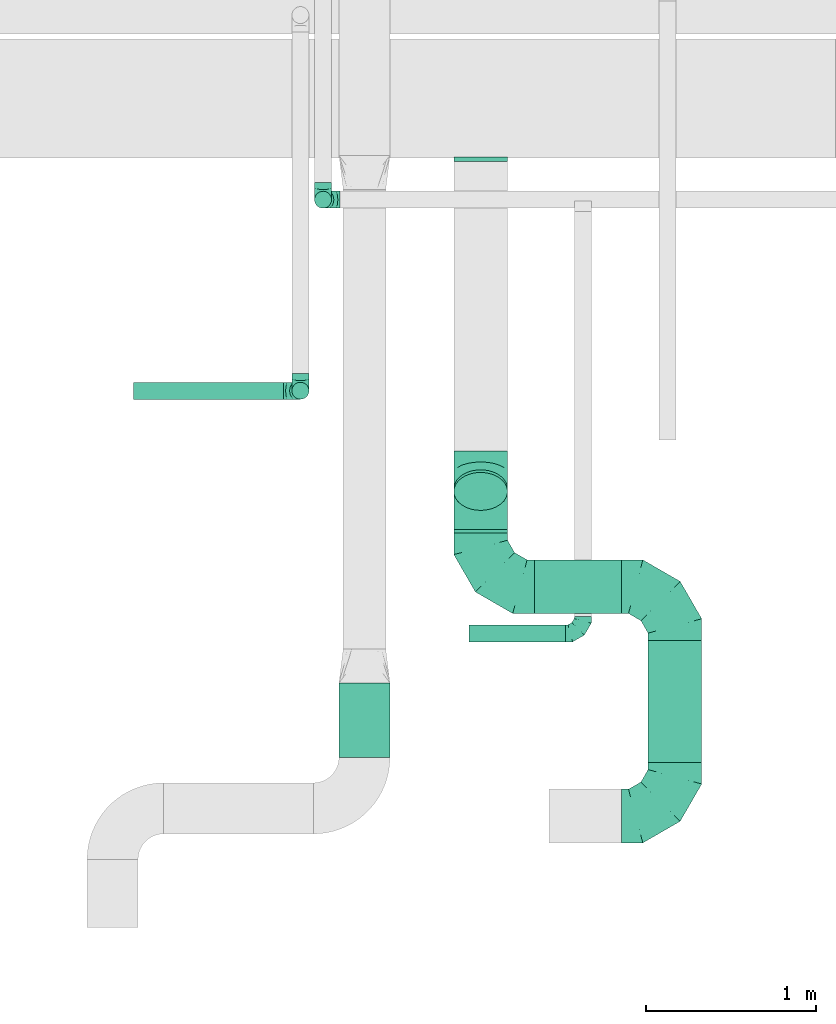
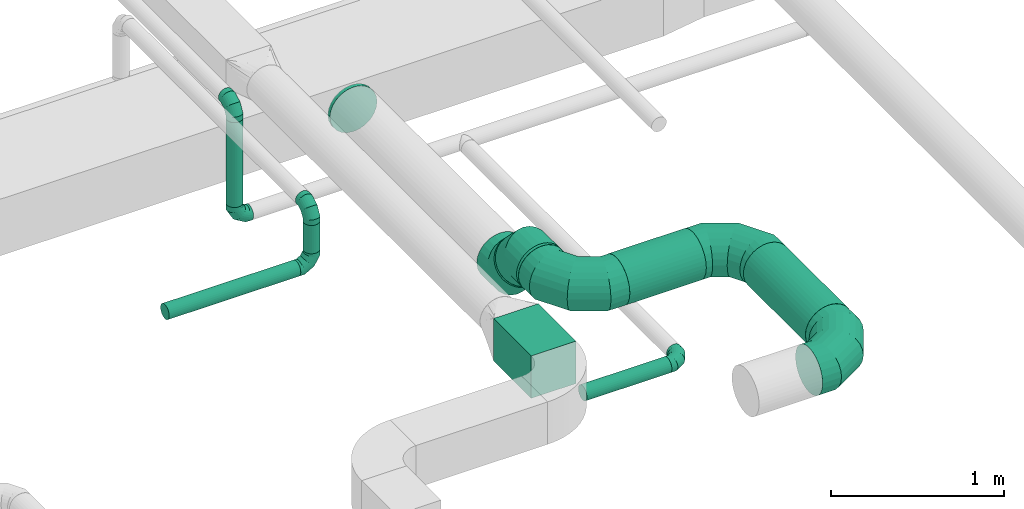
# One storey, part 35 of 60: 11 flow fittings, 9 flow segments.
"""IFC2X3 building model written with IfcOpenShell, lengths in millimetres."""

from ifc_helpers import new_model, entity, si_unit, converted_unit, derived_unit, direction, frame, origin, origin_2d_with_axis, place, context, subcontext, project, spatial, rectangle, circle, extrude, faceted_brep, source, transform, mapped, material, type_object, type_shapes, element, save


model = new_model("IFC2X3")

# Units and contexts
model_context = context("Model", 3, precision=0.01, world=origin(), true_north=direction((6.12303176911189e-17, 1.0)))
body_context = subcontext(model_context, "Body", "Model", "MODEL_VIEW")
ifc_project = project(units=[si_unit("LENGTHUNIT", "METRE", prefix="MILLI"), si_unit("AREAUNIT", "SQUARE_METRE"), si_unit("VOLUMEUNIT", "CUBIC_METRE"), converted_unit("PLANEANGLEUNIT", "DEGREE", entity("IfcRatioMeasure", 0.0174532925199433), si_unit("PLANEANGLEUNIT", "RADIAN"), dimensions=[0, 0, 0, 0, 0, 0, 0]), si_unit("MASSUNIT", "GRAM", prefix="KILO"), derived_unit("MASSDENSITYUNIT", [(si_unit("MASSUNIT", "GRAM", prefix="KILO"), 1), (si_unit("LENGTHUNIT", "METRE"), -3)]), derived_unit("MOMENTOFINERTIAUNIT", [(si_unit("LENGTHUNIT", "METRE"), 4)]), si_unit("TIMEUNIT", "SECOND"), si_unit("FREQUENCYUNIT", "HERTZ"), si_unit("THERMODYNAMICTEMPERATUREUNIT", "DEGREE_CELSIUS"), derived_unit("THERMALTRANSMITTANCEUNIT", [(si_unit("MASSUNIT", "GRAM", prefix="KILO"), 1), (si_unit("THERMODYNAMICTEMPERATUREUNIT", "KELVIN"), -1), (si_unit("TIMEUNIT", "SECOND"), -3)]), derived_unit("VOLUMETRICFLOWRATEUNIT", [(si_unit("LENGTHUNIT", "METRE"), 3), (si_unit("TIMEUNIT", "SECOND"), -1)]), derived_unit("MASSFLOWRATEUNIT", [(si_unit("MASSUNIT", "GRAM", prefix="KILO"), 1), (si_unit("TIMEUNIT", "SECOND"), -1)]), derived_unit("ROTATIONALFREQUENCYUNIT", [(si_unit("TIMEUNIT", "SECOND"), -1)]), si_unit("ELECTRICCURRENTUNIT", "AMPERE"), si_unit("ELECTRICVOLTAGEUNIT", "VOLT"), si_unit("POWERUNIT", "WATT"), si_unit("FORCEUNIT", "NEWTON", prefix="KILO"), si_unit("ILLUMINANCEUNIT", "LUX"), si_unit("LUMINOUSFLUXUNIT", "LUMEN"), si_unit("LUMINOUSINTENSITYUNIT", "CANDELA"), derived_unit("USERDEFINED", [(si_unit("MASSUNIT", "GRAM", prefix="KILO"), -1), (si_unit("LENGTHUNIT", "METRE"), -2), (si_unit("TIMEUNIT", "SECOND"), 3), (si_unit("LUMINOUSFLUXUNIT", "LUMEN"), 1)]), derived_unit("LINEARVELOCITYUNIT", [(si_unit("LENGTHUNIT", "METRE"), 1), (si_unit("TIMEUNIT", "SECOND"), -1)]), si_unit("PRESSUREUNIT", "PASCAL"), derived_unit("USERDEFINED", [(si_unit("LENGTHUNIT", "METRE"), -2), (si_unit("MASSUNIT", "GRAM", prefix="KILO"), 1), (si_unit("TIMEUNIT", "SECOND"), -2)]), derived_unit("LINEARFORCEUNIT", [(si_unit("MASSUNIT", "GRAM", prefix="KILO"), 1), (si_unit("LENGTHUNIT", "METRE"), 1), (si_unit("TIMEUNIT", "SECOND"), -2), (si_unit("LENGTHUNIT", "METRE"), -1)]), derived_unit("PLANARFORCEUNIT", [(si_unit("MASSUNIT", "GRAM", prefix="KILO"), 1), (si_unit("LENGTHUNIT", "METRE"), 1), (si_unit("TIMEUNIT", "SECOND"), -2), (si_unit("LENGTHUNIT", "METRE"), -2)])], contexts=[model_context])

# Site, building, storey
site_placement = place(None, origin())
site = spatial("IfcSite", under=ifc_project, at=site_placement, CompositionType="ELEMENT")
building_placement = place(site_placement, origin())
building = spatial("IfcBuilding", under=site, at=building_placement, CompositionType="ELEMENT")
storey_placement = place(building_placement, frame((0.0, 0.0, 19800.0)))
storey = spatial("IfcBuildingStorey", under=building, at=storey_placement, CompositionType="ELEMENT", Elevation=19800.0)

# Flow segments
duct_segment_type_1 = type_object("IfcDuctSegmentType", PredefinedType="NOTDEFINED")
flow_segment_1_placement = place(storey_placement, frame((50415.38, 4519.45, 3470.0)))
element("IfcFlowSegment", 1, at=flow_segment_1_placement, inside=storey, type_object=duct_segment_type_1, context=body_context, shape_type="SweptSolid", body=[
    extrude(rectangle(XDim=436.609622548939, YDim=300.000000000001, at=origin_2d_with_axis()), frame((150.0, 218.3, 0.0), z_axis=(0.0, 0.0, 1.0), x_axis=(0.0, -1.0, 0.0)), (0.0, 0.0, 1.0), 300.000000000001),
])
duct_segment_type_2 = type_object("IfcDuctSegmentType", PredefinedType="NOTDEFINED")
flow_segment_2_placement = place(storey_placement, frame((50270.37, 7743.75, 2900.0)))
element("IfcFlowSegment", 2, at=flow_segment_2_placement, inside=storey, type_object=duct_segment_type_2, context=body_context, shape_type="SweptSolid", body=[
    extrude(circle(Radius=50.0, at=origin_2d_with_axis()), frame((51.6, 51.6, 0.0), z_axis=(0.0, 0.0, 1.0), x_axis=(0.0, 1.0, 0.0)), (0.0, 0.0, 1.0), 599.999999999976),
])
flow_segment_3_placement = place(storey_placement, frame((51179.68, 5196.25, 2748.4)))
element("IfcFlowSegment", 3, at=flow_segment_3_placement, inside=storey, type_object=duct_segment_type_2, context=body_context, shape_type="SweptSolid", body=[
    extrude(circle(Radius=50.0, at=origin_2d_with_axis()), frame((0.0, 51.6, 51.6), z_axis=(1.0, 0.0, 0.0), x_axis=(0.0, 1.0, 0.0)), (0.0, 0.0, 1.0), 568.125000000038),
])
flow_segment_4_placement = place(storey_placement, frame((52230.09, 4489.45, 3140.9)))
element("IfcFlowSegment", 4, at=flow_segment_4_placement, inside=storey, type_object=duct_segment_type_2, context=body_context, shape_type="SweptSolid", body=[
    extrude(circle(Radius=157.5, at=origin_2d_with_axis()), frame((159.1, 0.0, 159.1), z_axis=(0.0, 1.0, 0.0), x_axis=(-1.0, 0.0, 0.0)), (0.0, 0.0, 1.0), 717.500000000009),
])
flow_segment_5_placement = place(storey_placement, frame((51562.93, 5362.86, 3140.9)))
element("IfcFlowSegment", 5, at=flow_segment_5_placement, inside=storey, type_object=duct_segment_type_2, context=body_context, shape_type="SweptSolid", body=[
    extrude(circle(Radius=157.5, at=origin_2d_with_axis()), frame((0.0, 159.1, 159.1), z_axis=(1.0, 0.0, 0.0), x_axis=(0.0, 1.0, 0.0)), (0.0, 0.0, 1.0), 511.250000000044),
])
flow_segment_6_placement = place(storey_placement, frame((51088.84, 5968.75, 3079.3)))
element("IfcFlowSegment", 6, at=flow_segment_6_placement, inside=storey, type_object=duct_segment_type_2, context=body_context, shape_type="SweptSolid", body=[
    extrude(circle(Radius=157.5, at=origin_2d_with_axis()), frame((159.1, 112.96, 128.44), z_axis=(0.0, 0.707106781186548, -0.707106781186548), x_axis=(-1.0, 0.0, 0.0)), (0.0, 0.0, 1.0), 21.8881681796214),
])
flow_segment_7_placement = place(storey_placement, frame((51088.84, 5836.95, 3140.9)))
element("IfcFlowSegment", 7, at=flow_segment_7_placement, inside=storey, type_object=duct_segment_type_2, context=body_context, shape_type="SweptSolid", body=[
    extrude(circle(Radius=157.5, at=origin_2d_with_axis()), frame((159.1, 0.0, 159.1), z_axis=(0.0, 1.0, 0.0), x_axis=(1.0, 0.0, 0.0)), (0.0, 0.0, 1.0), 22.0227278525114),
])
flow_segment_8_placement = place(storey_placement, frame((49209.05, 6621.41, 3148.4)))
element("IfcFlowSegment", 8, at=flow_segment_8_placement, inside=storey, type_object=duct_segment_type_2, context=body_context, shape_type="SweptSolid", body=[
    extrude(circle(Radius=50.0, at=origin_2d_with_axis()), frame((0.0, 51.6, 51.6), z_axis=(1.0, 0.0, 0.0), x_axis=(0.0, 1.0, 0.0)), (0.0, 0.0, 1.0), 880.000000000025),
])
flow_segment_9_placement = place(storey_placement, frame((50137.46, 6621.41, 3300.0)))
element("IfcFlowSegment", 9, at=flow_segment_9_placement, inside=storey, type_object=duct_segment_type_2, context=body_context, shape_type="SweptSolid", body=[
    extrude(circle(Radius=50.0, at=origin_2d_with_axis()), frame((51.6, 51.6, 0.0), z_axis=(0.0, 0.0, 1.0), x_axis=(0.0, 1.0, 0.0)), (0.0, 0.0, 1.0), 200.000000000015),
])

# Flow fittings
ifc_material = material()
duct_fitting_type_1 = type_object("IfcDuctFittingType", PredefinedType="NOTDEFINED", material=ifc_material)
shared_shape_1 = source(origin(), body_context, "Body", "Brep", [
    faceted_brep([(-100.0, 0.0, -50.0), (-100.0, -12.94, -48.3), (-100.0, -25.0, -43.3), (-100.0, -35.36, -35.36), (-100.0, -43.3, -25.0), (-100.0, -48.3, -12.94), (-100.0, -50.0, 0.0), (-100.0, -48.3, 12.94), (-100.0, -43.3, 25.0), (-100.0, -35.36, 35.36), (-100.0, -25.0, 43.3), (-100.0, -12.94, 48.3), (-100.0, 0.0, 50.0), (-100.0, 12.94, 48.3), (-100.0, 25.0, 43.3), (-100.0, 35.36, 35.36), (-100.0, 43.3, 25.0), (-100.0, 48.3, 12.94), (-100.0, 50.0, 0.0), (-100.0, 48.3, -12.94), (-100.0, 43.3, -25.0), (-100.0, 35.36, -35.36), (-100.0, 25.0, -43.3), (-100.0, 12.94, -48.3), (-76.67, 12.94, 48.3), (-79.9, 25.0, 43.3), (-73.21, 0.0, 50.0), (-82.68, 35.36, 35.36), (-86.15, 48.3, 12.94), (-86.6, 50.0, 0.0), (-84.81, 43.3, 25.0), (-84.81, 43.3, -25.0), (-82.68, 35.36, -35.36), (-86.15, 48.3, -12.94), (-76.67, 12.94, -48.3), (-73.21, 0.0, -50.0), (-79.9, 25.0, -43.3), (-69.74, -12.94, -48.3), (-66.51, -25.0, -43.3), (-63.73, -35.36, -35.36), (-61.6, -43.3, -25.0), (-60.26, -48.3, -12.94), (-59.81, -50.0, 0.0), (-60.26, -48.3, 12.94), (-61.6, -43.3, 25.0), (-63.73, -35.36, 35.36), (-66.51, -25.0, 43.3), (-69.74, -12.94, 48.3), (-36.27, 36.27, 48.3), (-45.1, 45.1, 43.3), (-26.79, 26.79, 50.0), (-52.68, 52.68, 35.36), (-58.49, 58.49, 25.0), (-62.15, 62.15, 12.94), (-63.4, 63.4, 0.0), (-62.15, 62.15, -12.94), (-58.49, 58.49, -25.0), (-52.68, 52.68, -35.36), (-36.27, 36.27, -48.3), (-26.79, 26.79, -50.0), (-45.1, 45.1, -43.3), (-17.32, 17.32, -48.3), (-8.49, 8.49, -43.3), (-0.91, 0.91, -35.36), (4.9, -4.9, -25.0), (8.56, -8.56, -12.94), (9.81, -9.81, 0.0), (8.56, -8.56, 12.94), (4.9, -4.9, 25.0), (-0.91, 0.91, 35.36), (-8.49, 8.49, 43.3), (-17.32, 17.32, 48.3), (-12.94, 76.67, 48.3), (-25.0, 79.9, 43.3), (0.0, 73.21, 50.0), (-35.36, 82.68, 35.36), (-43.3, 84.81, 25.0), (-48.3, 86.15, 12.94), (-50.0, 86.6, 0.0), (-48.3, 86.15, -12.94), (-43.3, 84.81, -25.0), (-35.36, 82.68, -35.36), (-12.94, 76.67, -48.3), (0.0, 73.21, -50.0), (-25.0, 79.9, -43.3), (12.94, 69.74, -48.3), (25.0, 66.51, -43.3), (35.36, 63.73, -35.36), (43.3, 61.6, -25.0), (48.3, 60.26, -12.94), (50.0, 59.81, 0.0), (48.3, 60.26, 12.94), (43.3, 61.6, 25.0), (35.36, 63.73, 35.36), (25.0, 66.51, 43.3), (12.94, 69.74, 48.3), (-12.94, 100.0, -48.3), (-25.0, 100.0, -43.3), (-35.36, 100.0, -35.36), (-43.3, 100.0, -25.0), (-48.3, 100.0, -12.94), (-50.0, 100.0, 0.0), (-48.3, 100.0, 12.94), (-43.3, 100.0, 25.0), (-35.36, 100.0, 35.36), (-25.0, 100.0, 43.3), (-12.94, 100.0, 48.3), (0.0, 100.0, 50.0), (12.94, 100.0, 48.3), (25.0, 100.0, 43.3), (35.36, 100.0, 35.36), (43.3, 100.0, 25.0), (48.3, 100.0, 12.94), (50.0, 100.0, 0.0), (48.3, 100.0, -12.94), (43.3, 100.0, -25.0), (35.36, 100.0, -35.36), (25.0, 100.0, -43.3), (12.94, 100.0, -48.3), (0.0, 100.0, -50.0)], [[[0, 1, 2, 3, 4, 5, 6, 7, 8, 9, 10, 11, 12, 13, 14, 15, 16, 17, 18, 19, 20, 21, 22, 23]], [[24, 25, 14, 13]], [[26, 24, 13, 12]], [[14, 25, 27, 15]], [[28, 29, 18, 17]], [[30, 28, 17, 16]], [[15, 27, 30, 16]], [[20, 31, 32, 21]], [[33, 31, 20, 19]], [[18, 29, 33, 19]], [[34, 35, 0, 23]], [[36, 34, 23, 22]], [[32, 36, 22, 21]], [[2, 1, 37, 38]], [[3, 2, 38, 39]], [[0, 35, 37, 1]], [[5, 4, 40, 41]], [[6, 5, 41, 42]], [[3, 39, 40, 4]], [[6, 42, 43, 7]], [[7, 43, 44, 8]], [[8, 44, 45, 9]], [[10, 46, 47, 11]], [[11, 47, 26, 12]], [[10, 9, 45, 46]], [[48, 49, 25, 24]], [[50, 48, 24, 26]], [[27, 25, 49, 51]], [[52, 53, 28, 30]], [[51, 52, 30, 27]], [[29, 28, 53, 54]], [[55, 56, 31, 33]], [[54, 55, 33, 29]], [[57, 32, 31, 56]], [[58, 59, 35, 34]], [[60, 58, 34, 36]], [[57, 60, 36, 32]], [[37, 35, 59, 61]], [[38, 37, 61, 62]], [[39, 38, 62, 63]], [[41, 40, 64, 65]], [[42, 41, 65, 66]], [[63, 64, 40, 39]], [[43, 42, 66, 67]], [[44, 43, 67, 68]], [[68, 69, 45, 44]], [[46, 45, 69, 70]], [[47, 46, 70, 71]], [[26, 47, 71, 50]], [[72, 73, 49, 48]], [[74, 72, 48, 50]], [[51, 49, 73, 75]], [[76, 77, 53, 52]], [[75, 76, 52, 51]], [[54, 53, 77, 78]], [[79, 80, 56, 55]], [[78, 79, 55, 54]], [[81, 57, 56, 80]], [[82, 83, 59, 58]], [[84, 82, 58, 60]], [[81, 84, 60, 57]], [[61, 59, 83, 85]], [[62, 61, 85, 86]], [[63, 62, 86, 87]], [[65, 64, 88, 89]], [[66, 65, 89, 90]], [[87, 88, 64, 63]], [[67, 66, 90, 91]], [[68, 67, 91, 92]], [[92, 93, 69, 68]], [[70, 69, 93, 94]], [[71, 70, 94, 95]], [[50, 71, 95, 74]], [[96, 97, 98, 99, 100, 101, 102, 103, 104, 105, 106, 107, 108, 109, 110, 111, 112, 113, 114, 115, 116, 117, 118, 119]], [[72, 74, 107, 106]], [[73, 72, 106, 105]], [[75, 73, 105, 104]], [[77, 76, 103, 102]], [[78, 77, 102, 101]], [[75, 104, 103, 76]], [[78, 101, 100, 79]], [[79, 100, 99, 80]], [[80, 99, 98, 81]], [[96, 119, 83, 82]], [[97, 96, 82, 84]], [[84, 81, 98, 97]], [[83, 119, 118, 85]], [[85, 118, 117, 86]], [[86, 117, 116, 87]], [[88, 115, 114, 89]], [[89, 114, 113, 90]], [[87, 116, 115, 88]], [[91, 90, 113, 112]], [[92, 91, 112, 111]], [[93, 92, 111, 110]], [[95, 94, 109, 108]], [[74, 95, 108, 107]], [[110, 109, 94, 93]]]),
])
type_shapes(duct_fitting_type_1, [shared_shape_1])
for number, where, z_axis, x_axis in (
    (10, (50321.97, 7795.34, 3600.0), (1.0, 0.0, 0.0), (0.0, -1.0, 0.0)),
    (11, (50321.97, 7795.34, 2800.0), (0.0, -1.0, 0.0), (0.0, 0.0, -1.0)),
):
    element("IfcFlowFitting", number, at=place(storey_placement, frame(where, z_axis=z_axis, x_axis=x_axis)), inside=storey, type_object=duct_fitting_type_1, material=ifc_material, context=body_context, shape_type="MappedRepresentation", body=[
        mapped(shared_shape_1, transform((0.0, 0.0, 0.0), scale=1.0)),
    ])
flow_fitting_1_placement = place(storey_placement, frame((51847.8, 5247.84, 2800.0)))
element("IfcFlowFitting", 12, at=flow_fitting_1_placement, inside=storey, type_object=duct_fitting_type_1, material=ifc_material, context=body_context, shape_type="MappedRepresentation", body=[
    mapped(shared_shape_1, transform((0.0, 0.0, 0.0), scale=1.0)),
])
for number, where, z_axis, x_axis in (
    (13, (50189.05, 6673.01, 3600.0), (1.0, 0.0, 0.0), (0.0, -1.0, 0.0)),
    (14, (50189.05, 6673.01, 3200.0), (0.0, 1.0, 0.0), (0.0, 0.0, -1.0)),
):
    element("IfcFlowFitting", number, at=place(storey_placement, frame(where, z_axis=z_axis, x_axis=x_axis)), inside=storey, type_object=duct_fitting_type_1, material=ifc_material, context=body_context, shape_type="MappedRepresentation", body=[
        mapped(shared_shape_1, transform((0.0, 0.0, 0.0), scale=1.0)),
    ])
duct_fitting_type_2 = type_object("IfcDuctFittingType", PredefinedType="NOTDEFINED", material=ifc_material)
shared_shape_2 = source(origin(), body_context, "Body", "Brep", [
    faceted_brep([(-315.0, 0.0, -157.5), (-315.0, -40.76, -152.13), (-315.0, -78.75, -136.4), (-315.0, -111.37, -111.37), (-315.0, -136.4, -78.75), (-315.0, -152.13, -40.76), (-315.0, -157.5, 0.0), (-315.0, -152.13, 40.76), (-315.0, -136.4, 78.75), (-315.0, -111.37, 111.37), (-315.0, -78.75, 136.4), (-315.0, -40.76, 152.13), (-315.0, 0.0, 157.5), (-315.0, 40.76, 152.13), (-315.0, 78.75, 136.4), (-315.0, 111.37, 111.37), (-315.0, 136.4, 78.75), (-315.0, 152.13, 40.76), (-315.0, 157.5, 0.0), (-315.0, 152.13, -40.76), (-315.0, 136.4, -78.75), (-315.0, 111.37, -111.37), (-315.0, 78.75, -136.4), (-315.0, 40.76, -152.13), (-241.52, 40.76, 152.13), (-251.7, 78.75, 136.4), (-230.6, 0.0, 157.5), (-260.44, 111.37, 111.37), (-271.36, 152.13, 40.76), (-272.8, 157.5, 0.0), (-267.14, 136.4, 78.75), (-267.14, 136.4, -78.75), (-260.44, 111.37, -111.37), (-271.36, 152.13, -40.76), (-241.52, 40.76, -152.13), (-230.6, 0.0, -157.5), (-251.7, 78.75, -136.4), (-219.67, -40.76, -152.13), (-209.5, -78.75, -136.4), (-200.75, -111.37, -111.37), (-194.05, -136.4, -78.75), (-189.83, -152.13, -40.76), (-188.39, -157.5, 0.0), (-189.83, -152.13, 40.76), (-194.05, -136.4, 78.75), (-200.75, -111.37, 111.37), (-209.5, -78.75, 136.4), (-219.67, -40.76, 152.13), (-114.25, 114.25, 152.13), (-142.05, 142.05, 136.4), (-84.4, 84.4, 157.5), (-165.93, 165.93, 111.37), (-184.25, 184.25, 78.75), (-195.77, 195.77, 40.76), (-199.7, 199.7, 0.0), (-195.77, 195.77, -40.76), (-184.25, 184.25, -78.75), (-165.93, 165.93, -111.37), (-114.25, 114.25, -152.13), (-84.4, 84.4, -157.5), (-142.05, 142.05, -136.4), (-54.56, 54.56, -152.13), (-26.75, 26.75, -136.4), (-2.88, 2.88, -111.37), (15.45, -15.45, -78.75), (26.97, -26.97, -40.76), (30.89, -30.89, 0.0), (26.97, -26.97, 40.76), (15.45, -15.45, 78.75), (-2.88, 2.88, 111.37), (-26.75, 26.75, 136.4), (-54.56, 54.56, 152.13), (-40.76, 241.52, 152.13), (-78.75, 251.7, 136.4), (0.0, 230.6, 157.5), (-111.37, 260.44, 111.37), (-136.4, 267.14, 78.75), (-152.13, 271.36, 40.76), (-157.5, 272.8, 0.0), (-152.13, 271.36, -40.76), (-136.4, 267.14, -78.75), (-111.37, 260.44, -111.37), (-40.76, 241.52, -152.13), (0.0, 230.6, -157.5), (-78.75, 251.7, -136.4), (40.76, 219.67, -152.13), (78.75, 209.5, -136.4), (111.37, 200.75, -111.37), (136.4, 194.05, -78.75), (152.13, 189.83, -40.76), (157.5, 188.39, 0.0), (152.13, 189.83, 40.76), (136.4, 194.05, 78.75), (111.37, 200.75, 111.37), (78.75, 209.5, 136.4), (40.76, 219.67, 152.13), (-40.76, 315.0, -152.13), (-78.75, 315.0, -136.4), (-111.37, 315.0, -111.37), (-136.4, 315.0, -78.75), (-152.13, 315.0, -40.76), (-157.5, 315.0, 0.0), (-152.13, 315.0, 40.76), (-136.4, 315.0, 78.75), (-111.37, 315.0, 111.37), (-78.75, 315.0, 136.4), (-40.76, 315.0, 152.13), (0.0, 315.0, 157.5), (40.76, 315.0, 152.13), (78.75, 315.0, 136.4), (111.37, 315.0, 111.37), (136.4, 315.0, 78.75), (152.13, 315.0, 40.76), (157.5, 315.0, 0.0), (152.13, 315.0, -40.76), (136.4, 315.0, -78.75), (111.37, 315.0, -111.37), (78.75, 315.0, -136.4), (40.76, 315.0, -152.13), (0.0, 315.0, -157.5)], [[[0, 1, 2, 3, 4, 5, 6, 7, 8, 9, 10, 11, 12, 13, 14, 15, 16, 17, 18, 19, 20, 21, 22, 23]], [[24, 25, 14, 13]], [[26, 24, 13, 12]], [[14, 25, 27, 15]], [[28, 29, 18, 17]], [[30, 28, 17, 16]], [[15, 27, 30, 16]], [[20, 31, 32, 21]], [[33, 31, 20, 19]], [[18, 29, 33, 19]], [[34, 35, 0, 23]], [[36, 34, 23, 22]], [[32, 36, 22, 21]], [[1, 0, 35, 37]], [[2, 1, 37, 38]], [[38, 39, 3, 2]], [[5, 4, 40, 41]], [[6, 5, 41, 42]], [[39, 40, 4, 3]], [[6, 42, 43, 7]], [[7, 43, 44, 8]], [[8, 44, 45, 9]], [[9, 45, 46, 10]], [[10, 46, 47, 11]], [[26, 12, 11, 47]], [[48, 49, 25, 24]], [[50, 48, 24, 26]], [[27, 25, 49, 51]], [[52, 53, 28, 30]], [[51, 52, 30, 27]], [[29, 28, 53, 54]], [[55, 56, 31, 33]], [[54, 55, 33, 29]], [[32, 31, 56, 57]], [[58, 59, 35, 34]], [[60, 58, 34, 36]], [[57, 60, 36, 32]], [[37, 35, 59, 61]], [[38, 37, 61, 62]], [[39, 38, 62, 63]], [[41, 40, 64, 65]], [[42, 41, 65, 66]], [[63, 64, 40, 39]], [[43, 42, 66, 67]], [[44, 43, 67, 68]], [[68, 69, 45, 44]], [[46, 45, 69, 70]], [[47, 46, 70, 71]], [[26, 47, 71, 50]], [[72, 73, 49, 48]], [[74, 72, 48, 50]], [[51, 49, 73, 75]], [[76, 77, 53, 52]], [[75, 76, 52, 51]], [[54, 53, 77, 78]], [[79, 80, 56, 55]], [[78, 79, 55, 54]], [[57, 56, 80, 81]], [[82, 83, 59, 58]], [[84, 82, 58, 60]], [[81, 84, 60, 57]], [[61, 59, 83, 85]], [[62, 61, 85, 86]], [[63, 62, 86, 87]], [[65, 64, 88, 89]], [[66, 65, 89, 90]], [[87, 88, 64, 63]], [[67, 66, 90, 91]], [[68, 67, 91, 92]], [[92, 93, 69, 68]], [[70, 69, 93, 94]], [[71, 70, 94, 95]], [[50, 71, 95, 74]], [[96, 97, 98, 99, 100, 101, 102, 103, 104, 105, 106, 107, 108, 109, 110, 111, 112, 113, 114, 115, 116, 117, 118, 119]], [[106, 105, 73, 72]], [[107, 106, 72, 74]], [[75, 73, 105, 104]], [[77, 76, 103, 102]], [[78, 77, 102, 101]], [[104, 103, 76, 75]], [[78, 101, 100, 79]], [[79, 100, 99, 80]], [[98, 81, 80, 99]], [[84, 97, 96, 82]], [[82, 96, 119, 83]], [[97, 84, 81, 98]], [[83, 119, 118, 85]], [[85, 118, 117, 86]], [[116, 87, 86, 117]], [[88, 115, 114, 89]], [[89, 114, 113, 90]], [[115, 88, 87, 116]], [[91, 90, 113, 112]], [[92, 91, 112, 111]], [[111, 110, 93, 92]], [[95, 94, 109, 108]], [[74, 95, 108, 107]], [[110, 109, 94, 93]]]),
])
type_shapes(duct_fitting_type_2, [shared_shape_2])
flow_fitting_2_placement = place(storey_placement, frame((52389.18, 5521.95, 3300.0), z_axis=(0.0, 0.0, 1.0), x_axis=(0.0, 1.0, 0.0)))
element("IfcFlowFitting", 15, at=flow_fitting_2_placement, inside=storey, type_object=duct_fitting_type_2, material=ifc_material, context=body_context, shape_type="MappedRepresentation", body=[
    mapped(shared_shape_2, transform((0.0, 0.0, 0.0), scale=1.0)),
])
flow_fitting_3_placement = place(storey_placement, frame((52389.18, 4174.45, 3300.0)))
element("IfcFlowFitting", 16, at=flow_fitting_3_placement, inside=storey, type_object=duct_fitting_type_2, material=ifc_material, context=body_context, shape_type="MappedRepresentation", body=[
    mapped(shared_shape_2, transform((0.0, 0.0, 0.0), scale=1.0)),
])
flow_fitting_4_placement = place(storey_placement, frame((51247.93, 5521.95, 3300.0), z_axis=(0.0, 0.0, 1.0), x_axis=(0.0, -1.0, 0.0)))
element("IfcFlowFitting", 17, at=flow_fitting_4_placement, inside=storey, type_object=duct_fitting_type_2, material=ifc_material, context=body_context, shape_type="MappedRepresentation", body=[
    mapped(shared_shape_2, transform((0.0, 0.0, 0.0), scale=1.0)),
])
duct_fitting_type_3 = type_object("IfcDuctFittingType", PredefinedType="NOTDEFINED", material=ifc_material)
shared_shape_3 = source(origin(), body_context, "Body", "Brep", [
    faceted_brep([(20.0, 40.76, -152.13), (20.0, 78.75, -136.4), (20.0, 111.37, -111.37), (20.0, 136.4, -78.75), (20.0, 152.13, -40.76), (20.0, 157.5, 0.0), (20.0, 152.13, 40.76), (20.0, 136.4, 78.75), (20.0, 111.37, 111.37), (20.0, 78.75, 136.4), (20.0, 40.76, 152.13), (20.0, 0.0, 157.5), (20.0, -40.76, 152.13), (20.0, -78.75, 136.4), (20.0, -111.37, 111.37), (20.0, -136.4, 78.75), (20.0, -152.13, 40.76), (20.0, -157.5, 0.0), (20.0, -152.13, -40.76), (20.0, -136.4, -78.75), (20.0, -111.37, -111.37), (20.0, -78.75, -136.4), (20.0, -40.76, -152.13), (20.0, 0.0, -157.5), (0.0, 0.0, 157.5), (0.0, 40.76, 152.13), (-6.1, 40.76, 152.13), (-6.1, 0.0, 157.5), (0.0, 78.75, 136.4), (-6.1, 78.75, 136.4), (0.0, 111.37, 111.37), (-6.1, 111.37, 111.37), (0.0, 136.4, 78.75), (0.0, 152.13, 40.76), (-6.1, 152.13, 40.76), (-6.1, 136.4, 78.75), (0.0, 157.5, 0.0), (-6.1, 157.5, 0.0), (0.0, 152.13, -40.76), (-6.1, 152.13, -40.76), (0.0, 136.4, -78.75), (-6.1, 136.4, -78.75), (0.0, 111.37, -111.37), (-6.1, 111.37, -111.37), (0.0, 0.0, -157.5), (-6.1, 0.0, -157.5), (-6.1, 40.76, -152.13), (0.0, 40.76, -152.13), (-6.1, 78.75, -136.4), (0.0, 78.75, -136.4), (0.0, -40.76, -152.13), (-6.1, -40.76, -152.13), (0.0, -78.75, -136.4), (-6.1, -78.75, -136.4), (0.0, -111.37, -111.37), (-6.1, -111.37, -111.37), (0.0, -136.4, -78.75), (0.0, -152.13, -40.76), (-6.1, -152.13, -40.76), (-6.1, -136.4, -78.75), (0.0, -157.5, 0.0), (-6.1, -157.5, 0.0), (0.0, -152.13, 40.76), (-6.1, -152.13, 40.76), (0.0, -136.4, 78.75), (-6.1, -136.4, 78.75), (0.0, -111.37, 111.37), (-6.1, -111.37, 111.37), (0.0, -78.75, 136.4), (0.0, -40.76, 152.13), (-6.1, -40.76, 152.13), (-6.1, -78.75, 136.4)], [[[0, 1, 2, 3, 4, 5, 6, 7, 8, 9, 10, 11, 12, 13, 14, 15, 16, 17, 18, 19, 20, 21, 22, 23]], [[24, 11, 10, 25, 26, 27]], [[25, 10, 9, 28, 29, 26]], [[28, 9, 8, 30, 31, 29]], [[32, 7, 6, 33, 34, 35]], [[33, 6, 5, 36, 37, 34]], [[30, 8, 7, 32, 35, 31]], [[36, 5, 4, 38, 39, 37]], [[38, 4, 3, 40, 41, 39]], [[40, 3, 2, 42, 43, 41]], [[0, 23, 44, 45, 46, 47]], [[1, 0, 47, 46, 48, 49]], [[49, 48, 43, 42, 2, 1]], [[44, 23, 22, 50, 51, 45]], [[50, 22, 21, 52, 53, 51]], [[52, 21, 20, 54, 55, 53]], [[56, 19, 18, 57, 58, 59]], [[57, 18, 17, 60, 61, 58]], [[54, 20, 19, 56, 59, 55]], [[60, 17, 16, 62, 63, 61]], [[62, 16, 15, 64, 65, 63]], [[64, 15, 14, 66, 67, 65]], [[68, 13, 12, 69, 70, 71]], [[69, 12, 11, 24, 27, 70]], [[66, 14, 13, 68, 71, 67]], [[45, 51, 53, 55, 59, 58, 61, 63, 65, 67, 71, 70, 27, 26, 29, 31, 35, 34, 37, 39, 41, 43, 48, 46]]]),
])
type_shapes(duct_fitting_type_3, [shared_shape_3])
flow_fitting_5_placement = place(storey_placement, frame((51247.93, 8039.45, 3099.95), z_axis=(0.0, 0.0, -1.0), x_axis=(0.0, -1.0, 0.0)))
element("IfcFlowFitting", 18, at=flow_fitting_5_placement, inside=storey, type_object=duct_fitting_type_3, material=ifc_material, context=body_context, shape_type="MappedRepresentation", body=[
    mapped(shared_shape_3, transform((0.0, 0.0, 0.0), scale=1.0)),
])
duct_fitting_type_4 = type_object("IfcDuctFittingType", PredefinedType="NOTDEFINED", material=ifc_material)
shared_shape_4 = source(origin(), body_context, "Body", "Brep", [
    faceted_brep([(-130.48, 0.0, -157.5), (-130.48, -40.76, -152.13), (-130.48, -78.75, -136.4), (-130.48, -111.37, -111.37), (-130.48, -136.4, -78.75), (-130.48, -152.13, -40.76), (-130.48, -157.5, 0.0), (-130.48, -152.13, 40.76), (-130.48, -136.4, 78.75), (-130.48, -111.37, 111.37), (-130.48, -78.75, 136.4), (-130.48, -40.76, 152.13), (-130.48, 0.0, 157.5), (-130.48, 40.76, 152.13), (-130.48, 78.75, 136.4), (-130.48, 111.37, 111.37), (-130.48, 136.4, 78.75), (-130.48, 152.13, 40.76), (-130.48, 157.5, 0.0), (-130.48, 152.13, -40.76), (-130.48, 136.4, -78.75), (-130.48, 111.37, -111.37), (-130.48, 78.75, -136.4), (-130.48, 40.76, -152.13), (-16.89, 40.76, 152.13), (-32.62, 78.75, 136.4), (0.0, 0.0, 157.5), (-46.13, 111.37, 111.37), (-63.02, 152.13, 40.76), (-65.24, 157.5, 0.0), (-56.5, 136.4, 78.75), (-56.5, 136.4, -78.75), (-46.13, 111.37, -111.37), (-63.02, 152.13, -40.76), (-16.89, 40.76, -152.13), (0.0, 0.0, -157.5), (-32.62, 78.75, -136.4), (16.89, -40.76, -152.13), (32.62, -78.75, -136.4), (46.13, -111.37, -111.37), (56.5, -136.4, -78.75), (63.02, -152.13, -40.76), (65.24, -157.5, 0.0), (63.02, -152.13, 40.76), (56.5, -136.4, 78.75), (46.13, -111.37, 111.37), (32.62, -78.75, 136.4), (16.89, -40.76, 152.13), (92.26, 92.26, 157.5), (63.44, 121.09, 152.13), (36.58, 147.95, 136.4), (13.51, 171.01, 111.37), (-4.19, 188.71, 78.75), (-15.31, 199.84, 40.76), (-19.11, 203.63, 0.0), (-15.31, 199.84, -40.76), (-4.19, 188.71, -78.75), (13.51, 171.01, -111.37), (36.58, 147.95, -136.4), (63.44, 121.09, -152.13), (92.26, 92.26, -157.5), (121.09, 63.44, -152.13), (147.95, 36.58, -136.4), (171.01, 13.51, -111.37), (188.71, -4.19, -78.75), (199.84, -15.31, -40.76), (203.63, -19.11, 0.0), (199.84, -15.31, 40.76), (188.71, -4.19, 78.75), (171.01, 13.51, 111.37), (147.95, 36.58, 136.4), (121.09, 63.44, 152.13)], [[[0, 1, 2, 3, 4, 5, 6, 7, 8, 9, 10, 11, 12, 13, 14, 15, 16, 17, 18, 19, 20, 21, 22, 23]], [[24, 25, 14, 13]], [[26, 24, 13, 12]], [[14, 25, 27, 15]], [[28, 29, 18, 17]], [[30, 28, 17, 16]], [[15, 27, 30, 16]], [[20, 31, 32, 21]], [[33, 31, 20, 19]], [[18, 29, 33, 19]], [[34, 35, 0, 23]], [[36, 34, 23, 22]], [[32, 36, 22, 21]], [[1, 0, 35, 37]], [[2, 1, 37, 38]], [[38, 39, 3, 2]], [[5, 4, 40, 41]], [[6, 5, 41, 42]], [[39, 40, 4, 3]], [[6, 42, 43, 7]], [[7, 43, 44, 8]], [[8, 44, 45, 9]], [[9, 45, 46, 10]], [[10, 46, 47, 11]], [[26, 12, 11, 47]], [[24, 26, 48, 49]], [[25, 24, 49, 50]], [[27, 25, 50, 51]], [[28, 30, 52, 53]], [[29, 28, 53, 54]], [[51, 52, 30, 27]], [[55, 56, 31, 33]], [[54, 55, 33, 29]], [[57, 32, 31, 56]], [[36, 58, 59, 34]], [[34, 59, 60, 35]], [[58, 36, 32, 57]], [[35, 60, 61, 37]], [[37, 61, 62, 38]], [[63, 39, 38, 62]], [[40, 64, 65, 41]], [[41, 65, 66, 42]], [[64, 40, 39, 63]], [[43, 42, 66, 67]], [[44, 43, 67, 68]], [[68, 69, 45, 44]], [[47, 46, 70, 71]], [[26, 47, 71, 48]], [[69, 70, 46, 45]], [[54, 53, 52, 51, 50, 49, 48, 71, 70, 69, 68, 67, 66, 65, 64, 63, 62, 61, 60, 59, 58, 57, 56, 55]]]),
])
type_shapes(duct_fitting_type_4, [shared_shape_4])
for number, where, z_axis, x_axis in (
    (19, (51247.93, 6189.45, 3100.0), (-1.0, 0.0, 0.0), (0.0, -1.0, 0.0)),
    (20, (51247.93, 5989.45, 3300.0), (1.0, 0.0, 0.0), (0.0, -0.707106781186226, 0.707106781186869)),
):
    element("IfcFlowFitting", number, at=place(storey_placement, frame(where, z_axis=z_axis, x_axis=x_axis)), inside=storey, type_object=duct_fitting_type_4, material=ifc_material, context=body_context, shape_type="MappedRepresentation", body=[
        mapped(shared_shape_4, transform((0.0, 0.0, 0.0), scale=1.0)),
    ])

save(model, "model.ifc")
